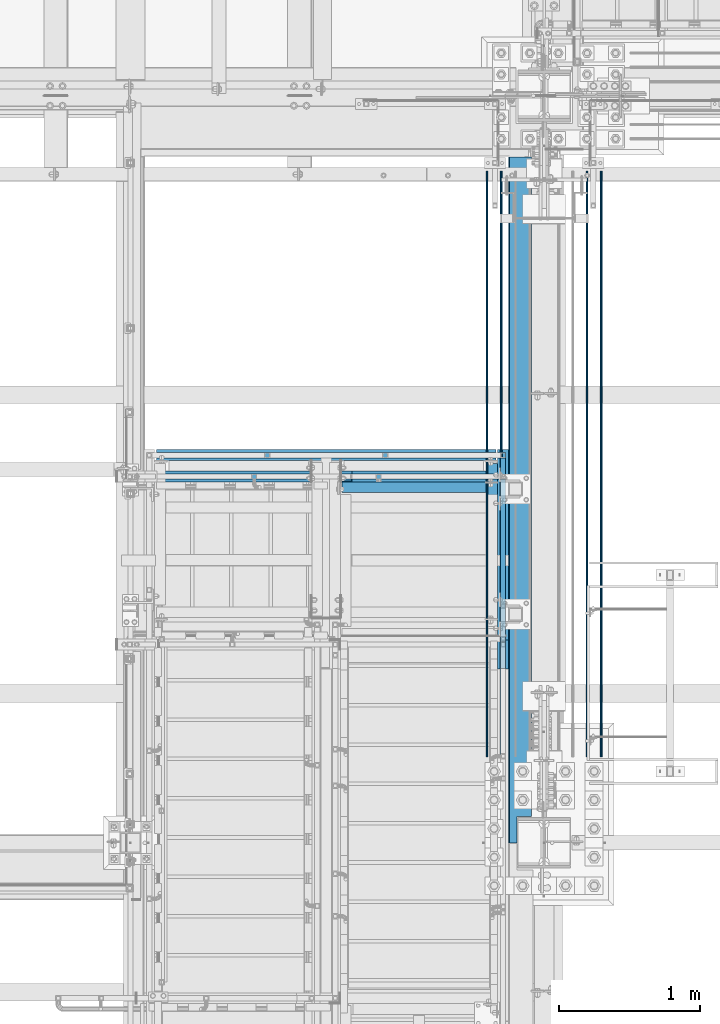
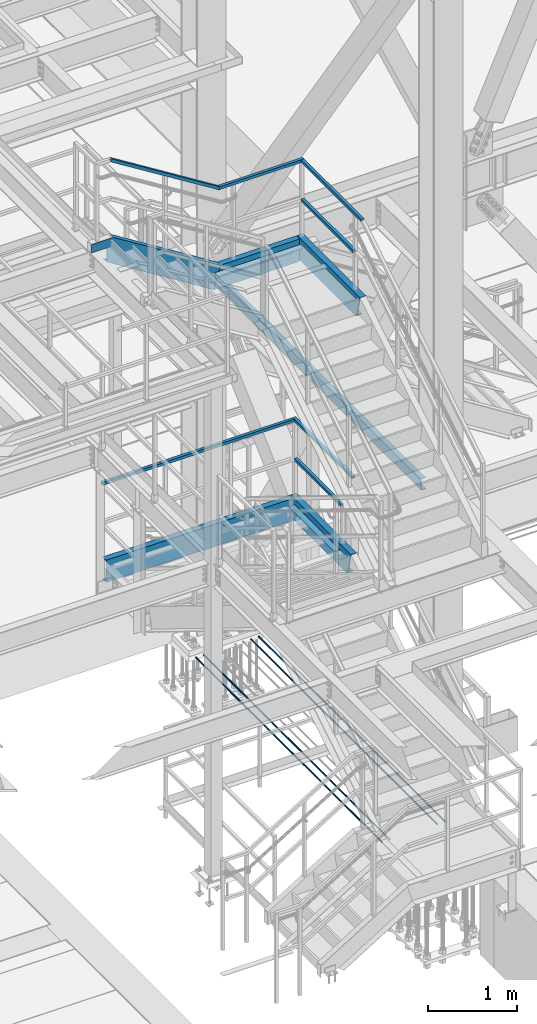
# One storey, part 1776 of 3843: 17 beams, 2 members, 13 elements without a shape of their own.
"""IFC2X3 building model written with IfcOpenShell, lengths in millimetres."""

from ifc_helpers import new_model, si_unit, frame, origin_with_axes, place, context, subcontext, project, spatial, faceted_brep, material, type_object, element, aggregate, save


model = new_model("IFC2X3")

# Units and contexts
model_context = context("Model", 3, precision=1e-05, world=origin_with_axes())
body_context = subcontext(model_context, "Body", "Model", "MODEL_VIEW")
ifc_project = project(units=[si_unit("LENGTHUNIT", "METRE", prefix="MILLI"), si_unit("AREAUNIT", "SQUARE_METRE"), si_unit("VOLUMEUNIT", "CUBIC_METRE"), si_unit("MASSUNIT", "GRAM", prefix="KILO"), si_unit("TIMEUNIT", "SECOND"), si_unit("PLANEANGLEUNIT", "RADIAN"), si_unit("SOLIDANGLEUNIT", "STERADIAN"), si_unit("THERMODYNAMICTEMPERATUREUNIT", "DEGREE_CELSIUS"), si_unit("LUMINOUSINTENSITYUNIT", "LUMEN")], contexts=[model_context])

# Site, building, storey
site_placement = place(None, origin_with_axes())
site = spatial("IfcSite", under=ifc_project, at=site_placement, CompositionType="ELEMENT")
building_placement = place(site_placement, origin_with_axes())
building = spatial("IfcBuilding", under=site, at=building_placement, Name="Undefined", CompositionType="ELEMENT")
storey_placement = place(building_placement, origin_with_axes())
storey = spatial("IfcBuildingStorey", under=building, at=storey_placement, Name="Undefined", CompositionType="ELEMENT", Elevation=0.0)

# Assembly, beam
assembly_1_placement = place(storey_placement, origin_with_axes())
assembly_1 = element("IfcElementAssembly", 1, at=assembly_1_placement, inside=storey, Name="RAIL", AssemblyPlace="NOTDEFINED", PredefinedType="RIGID_FRAME")
ifc_material_1 = material()
beam_type_1 = type_object("IfcBeamType", Name="HSS1-1/2X1-1/2X1/4", PredefinedType="NOTDEFINED")
beam_1_placement = place(assembly_1_placement, frame((55638.7, 22910.8000000047, 37761.333331298), z_axis=(0.0, 0.0, 1.0), x_axis=(-1.0, 0.0, 0.0)))
beam_1 = element("IfcBeam", 2, at=beam_1_placement, type_object=beam_type_1, material=ifc_material_1, Name="RAIL", ObjectType="HSS1-1/2X1-1/2X1/4", context=body_context, shape_type="Brep", body=[
    faceted_brep([(12.6999993300196, 12.6999993299978, -12.6999993300014), (12.6999993300014, -12.6999993299978, -12.6999993300014), (1083.13856710227, -12.6999993300014, -12.6999993299978), (1083.13856710227, 12.6999993300014, -12.6999993299978), (-12.699999329976, -12.6999993299978, 12.6999993300014), (1075.86143299826, -12.6999993300014, 12.6999993299978), (-12.6999993300014, 12.6999993299978, 12.6999993300014), (1075.86143299826, 12.6999993300014, 12.6999993299978), (19.0499992350015, 19.0499992350015, -19.0499992350015), (-19.0499992350015, 19.0499992350015, 19.0499992350015), (1074.0421494035, 19.0499992350015, 19.0499992350015), (1084.95785069704, 19.0499992350015, -19.0499992350015), (-19.0499992349796, -19.0499992350015, 19.0499992350015), (1074.0421494035, -19.0499992350015, 19.0499992350015), (19.0499992350015, -19.0499992350015, -19.0499992350015), (1084.95785069704, -19.0499992350015, -19.0499992350015)], [[[0, 1, 2, 3]], [[1, 4, 5, 2]], [[4, 6, 7, 5]], [[6, 0, 3, 7]], [[8, 9, 10, 11]], [[9, 12, 13, 10]], [[12, 14, 15, 13]], [[14, 8, 11, 15]], [[13, 15, 11, 10], [5, 7, 3, 2]], [[14, 12, 9, 8], [6, 4, 1, 0]]]),
])

# Assembly, beams
assembly_2_placement = place(storey_placement, origin_with_axes())
assembly_2 = element("IfcElementAssembly", 3, at=assembly_2_placement, inside=storey, Name="RAIL", AssemblyPlace="NOTDEFINED", PredefinedType="RIGID_FRAME")
beam_2_placement = place(assembly_2_placement, frame((55638.7, 21717.0000000047, 37227.933331298), z_axis=(0.0, 0.0, 1.0), x_axis=(0.0, 1.0, 0.0)))
beam_2 = element("IfcBeam", 4, at=beam_2_placement, type_object=beam_type_1, material=ifc_material_1, Name="RAIL", ObjectType="HSS1-1/2X1-1/2X1/4", context=body_context, shape_type="Brep", body=[
    faceted_brep([(1174.75000001042, -19.0500000010288, 19.0499992350015), (1174.75000001042, -19.0499992350015, -19.0499992350015), (1174.74999999997, 19.0499992350015, -19.0499992350015), (1174.74999999997, 19.0499992350015, 19.0499992350015), (1174.75000001042, -12.6999993299978, 12.6999993299978), (1174.75000001042, 12.6999993299978, 12.6999993299978), (1174.75000001042, 12.6999993299978, -12.6999993299978), (1174.75000001042, -12.6999993299978, -12.6999993299978), (19.0499992350015, 19.0499992350015, 19.0499992350015), (19.0499992350015, -19.0499992350015, 19.0499992350015), (19.0499992350015, -19.0499992350015, -19.0499992350015), (19.0499992350015, 19.0499992350015, -19.0499992350015), (19.0499992350015, 12.6999993299978, 12.6999993299978), (19.0499992350015, -12.6999993299978, 12.6999993299978), (19.0499992350015, -12.6999993299978, -12.6999993299978), (19.0499992350015, 12.6999993299978, -12.6999993299978)], [[[0, 1, 2, 3], [4, 5, 6, 7]], [[8, 9, 0, 3]], [[10, 11, 2, 1]], [[9, 10, 1, 0]], [[11, 8, 3, 2]], [[10, 9, 8, 11], [12, 13, 14, 15]], [[14, 13, 4, 7]], [[15, 14, 7, 6]], [[12, 15, 6, 5]], [[13, 12, 5, 4]]]),
])
beam_3_placement = place(assembly_2_placement, frame((55638.7, 22910.8000000047, 37761.333331298), z_axis=(0.0, 0.0, -1.0), x_axis=(0.0, -1.0, 0.0)))
beam_3 = element("IfcBeam", 5, at=beam_3_placement, type_object=beam_type_1, material=ifc_material_1, Name="RAIL", ObjectType="HSS1-1/2X1-1/2X1/4", context=body_context, shape_type="Brep", body=[
    faceted_brep([(19.0499992350015, 12.6999993299978, -12.6999993299978), (19.0499992350015, -12.6999993299978, -12.6999993299978), (1362.53856701089, -12.6999993299978, -12.6999993299978), (1362.53856701089, 12.6999993299978, -12.6999993299978), (19.0499992350015, -12.6999993299978, 12.6999993299978), (1355.26143290688, -12.6999993299978, 12.6999993299978), (19.0499992350015, 12.6999993299978, 12.6999993299978), (1355.26143290688, 12.6999993299978, 12.6999993299978), (19.0499992350015, 19.0499992350015, -19.0499992350015), (19.0499992350015, 19.0499992350015, 19.0499992350015), (1353.44214931212, 19.0499992350015, 19.0499992350015), (1364.35785060565, 19.0499992350015, -19.0499992350015), (19.0499992350015, -19.0499992350015, 19.0499992350015), (1353.44214931212, -19.0499992350015, 19.0499992350015), (19.0499992350015, -19.0499992350015, -19.0499992350015), (1364.35785060565, -19.0499992350015, -19.0499992350015)], [[[0, 1, 2, 3]], [[1, 4, 5, 2]], [[4, 6, 7, 5]], [[6, 0, 3, 7]], [[8, 9, 10, 11]], [[9, 12, 13, 10]], [[12, 14, 15, 13]], [[14, 8, 11, 15]], [[13, 15, 11, 10], [5, 7, 3, 2]], [[14, 12, 9, 8], [6, 4, 1, 0]]]),
])
aggregate(assembly_2, [beam_2, beam_3])

# Assembly, beam
assembly_3_placement = place(storey_placement, origin_with_axes())
assembly_3 = element("IfcElementAssembly", 6, at=assembly_3_placement, inside=storey, Name="RAIL", AssemblyPlace="NOTDEFINED", PredefinedType="RIGID_FRAME")
beam_4_placement = place(assembly_3_placement, frame((55638.6999999997, 23063.2000000032, 34125.8769212707), z_axis=(0.0, 0.0, -1.0), x_axis=(-1.0, 0.0, 0.0)))
beam_4 = element("IfcBeam", 7, at=beam_4_placement, type_object=beam_type_1, material=ifc_material_1, Name="RAIL", ObjectType="HSS1-1/2X1-1/2X1/4", context=body_context, shape_type="Brep", body=[
    faceted_brep([(19.0499992350015, 12.6999993299978, -12.6999993299978), (19.0499992350015, -12.6999993299978, -12.6999993299978), (2495.55000076468, -12.6999993300014, -12.6999993299978), (2495.55000076468, 12.6999993300014, -12.6999993299978), (19.0499992350015, -12.6999993299978, 12.6999993299978), (2495.55000076468, -12.6999993300014, 12.6999993299978), (19.0499992350015, 12.6999993299978, 12.6999993299978), (2495.55000076468, 12.6999993300014, 12.6999993299978), (19.0499992350015, 19.0499992350015, -19.0499992350015), (19.0499992350015, 19.0499992350015, 19.0499992350015), (2495.55000076468, 19.0499992350015, 19.0499992350015), (2495.55000076468, 19.0499992350015, -19.0499992350015), (19.0499992350015, -19.0499992350015, 19.0499992350015), (2495.55000076468, -19.0499992350015, 19.0499992350015), (19.0499992350015, -19.0499992350015, -19.0499992350015), (2495.55000076468, -19.0499992350015, -19.0499992350015)], [[[0, 1, 2, 3]], [[1, 4, 5, 2]], [[4, 6, 7, 5]], [[6, 0, 3, 7]], [[8, 9, 10, 11]], [[9, 12, 13, 10]], [[12, 14, 15, 13]], [[14, 8, 11, 15]], [[13, 15, 11, 10], [5, 7, 3, 2]], [[14, 12, 9, 8], [6, 4, 1, 0]]]),
])
aggregate(assembly_3, [beam_4])

# Assembly, beams
assembly_4_placement = place(storey_placement, origin_with_axes())
assembly_4 = element("IfcElementAssembly", 8, at=assembly_4_placement, inside=storey, Name="RAIL", AssemblyPlace="NOTDEFINED", PredefinedType="RIGID_FRAME")
beam_5_placement = place(assembly_4_placement, frame((55638.7000000001, 21993.2250000126, 33592.4769212961), z_axis=(0.0, 0.0, 1.0), x_axis=(0.0, 1.0, 0.0)))
beam_5 = element("IfcBeam", 9, at=beam_5_placement, type_object=beam_type_1, material=ifc_material_1, Name="RAIL", ObjectType="HSS1-1/2X1-1/2X1/4", context=body_context, shape_type="Brep", body=[
    faceted_brep([(19.0499992350015, 12.6999993299978, -12.6999993299978), (19.0499992350015, -12.6999993299978, -12.6999993299978), (1050.92500075131, -12.6999993299978, -12.6999993299978), (1050.92500075131, 12.6999993299978, -12.6999993299978), (19.0499992350015, -12.6999993299978, 12.6999993299978), (1050.92500075131, -12.6999993299978, 12.6999993299978), (19.0499992350015, 12.6999993299978, 12.6999993299978), (1050.92500075131, 12.6999993299978, 12.6999993299978), (19.0499992350015, 19.0499992350015, -19.0499992350015), (19.0499992350015, 19.0499992350015, 19.0499992350015), (1050.92500075131, 19.0499992350015, 19.0499992350015), (1050.92500075131, 19.0499992350015, -19.0499992350015), (19.0499992350015, -19.0499992350015, 19.0499992350015), (1050.92500075131, -19.0499992350015, 19.0499992350015), (19.0499992350015, -19.0499992350015, -19.0499992350015), (1050.92500075131, -19.0499992350015, -19.0499992350015)], [[[0, 1, 2, 3]], [[1, 4, 5, 2]], [[4, 6, 7, 5]], [[6, 0, 3, 7]], [[8, 9, 10, 11]], [[9, 12, 13, 10]], [[12, 14, 15, 13]], [[14, 8, 11, 15]], [[13, 15, 11, 10], [5, 7, 3, 2]], [[14, 12, 9, 8], [6, 4, 1, 0]]]),
])
beam_6_placement = place(assembly_4_placement, frame((55638.6999999997, 23063.2000000032, 34125.8769212707), z_axis=(0.0, 0.0, -1.0), x_axis=(0.0, -1.0, 0.0)))
beam_6 = element("IfcBeam", 10, at=beam_6_placement, type_object=beam_type_1, material=ifc_material_1, Name="RAIL", ObjectType="HSS1-1/2X1-1/2X1/4", context=body_context, shape_type="Brep", body=[
    faceted_brep([(-12.6999993309546, 12.6999993299978, -12.6999993299978), (-12.6999993309546, -12.6999993299978, -12.6999993299978), (1311.69463514075, -12.6999993299978, -12.6999993299978), (1311.69463514075, 12.6999993299978, -12.6999993299978), (12.6999993290483, -12.6999993299978, 12.6999993299978), (1304.50536389938, -12.6999993299978, 12.6999993299978), (12.6999993290483, 12.6999993299978, 12.6999993299978), (1304.50536389938, 12.6999993299978, 12.6999993299978), (-19.0499992359546, 19.0499992350015, -19.0499992350015), (19.0499992350015, 19.0499992350015, 19.0499992350015), (1302.70804602111, 19.0499992350015, 19.0499992350015), (1313.49195301902, 19.0499992350015, -19.0499992350015), (19.0499992350015, -19.0499992350015, 19.0499992350015), (1302.70804602111, -19.0499992350015, 19.0499992350015), (-19.0499992359546, -19.0499992350015, -19.0499992350015), (1313.49195301902, -19.0499992350015, -19.0499992350015)], [[[0, 1, 2, 3]], [[1, 4, 5, 2]], [[4, 6, 7, 5]], [[6, 0, 3, 7]], [[8, 9, 10, 11]], [[9, 12, 13, 10]], [[12, 14, 15, 13]], [[14, 8, 11, 15]], [[13, 15, 11, 10], [5, 7, 3, 2]], [[14, 12, 9, 8], [6, 4, 1, 0]]]),
])
aggregate(assembly_4, [beam_5, beam_6])

# Member
member_type_1 = type_object("IfcMemberType", Name="HSS1-1/2X1-1/2X1/4", PredefinedType="NOTDEFINED")
member_1_placement = place(assembly_1_placement, frame((53162.1999991106, 22910.8000000151, 38633.3999983557), z_axis=(-0.529536736899114, 0.0, -0.848287005838377), x_axis=(0.848287005838377, 0.0, -0.529536736899114)))
member_1 = element("IfcMember", 11, at=member_1_placement, type_object=member_type_1, material=ifc_material_1, Name="RAIL", ObjectType="HSS1-1/2X1-1/2X1/4", context=body_context, shape_type="Brep", body=[
    faceted_brep([(-3.63856705526268, 12.6999993300014, -12.6999993299469), (-3.63856705526268, -12.6999993300014, -12.6999993299469), (1643.20971803503, -12.6999993300014, -12.699999331875), (1643.20971803503, 12.6999993300014, -12.699999331875), (3.63856705247599, -12.6999993300014, 12.6999993299542), (1650.48685214277, -12.6999993300014, 12.699999328026), (3.63856705247599, 12.6999993300014, 12.6999993299542), (1650.48685214277, 12.6999993300014, 12.699999328026), (-5.45785065095697, 19.0499992350015, -19.0499992349214), (5.45785064817028, 19.0499992350015, 19.0499992349287), (1652.30613573846, 19.0499992350015, 19.0499992329933), (1641.39043443933, 19.0499992350015, -19.0499992368568), (5.45785064817028, -19.0499992350015, 19.0499992349287), (1652.30613573846, -19.0499992350015, 19.0499992329933), (-5.45785065095697, -19.0499992350015, -19.0499992349214), (1641.39043443933, -19.0499992350015, -19.0499992368568)], [[[0, 1, 2, 3]], [[1, 4, 5, 2]], [[4, 6, 7, 5]], [[6, 0, 3, 7]], [[8, 9, 10, 11]], [[9, 12, 13, 10]], [[12, 14, 15, 13]], [[14, 8, 11, 15]], [[13, 15, 11, 10], [5, 7, 3, 2]], [[14, 12, 9, 8], [6, 4, 1, 0]]]),
])

aggregate(assembly_1, [beam_1, member_1])

# Assembly, beam
assembly_5_placement = place(storey_placement, origin_with_axes())
assembly_5 = element("IfcElementAssembly", 12, at=assembly_5_placement, inside=storey, Name="STAIR", AssemblyPlace="NOTDEFINED", PredefinedType="RIGID_FRAME")
ifc_material_2 = material(Name="STEEL/A36")
beam_type_2 = type_object("IfcBeamType", Name="C12X20.7", PredefinedType="NOTDEFINED")
beam_7_placement = place(assembly_5_placement, frame((55600.5999999997, 22910.8000000628, 36567.5333312657), z_axis=(0.0, 0.0, 1.0), x_axis=(-1.0, 0.0, 0.0)))
beam_7 = element("IfcBeam", 13, at=beam_7_placement, type_object=beam_type_2, material=ifc_material_2, Name="STAIR", ObjectType="C12X20.7", context=body_context, shape_type="Brep", body=[
    faceted_brep([(12.7000000007174, 38.0999999999985, -152.400000000001), (12.7000000007174, 38.0999999999985, 152.400000000001), (1034.12286550141, 38.0999999999985, 152.400000000001), (1121.44847935647, 38.0999999999985, -152.400000000001), (12.7000000007174, -38.0999999999985, 152.400000000001), (1034.12286550141, -38.0999999999985, 152.400000000001), (12.7000000007174, -38.0999999999985, 146.047460000002), (1035.94287683684, -38.0999999999985, 146.047460000002), (12.7000000007174, 30.1624999999985, 134.674927499997), (1039.20112283962, 30.1624999999985, 134.674927499997), (12.7000000007174, 30.1624999999985, -134.674927499997), (1116.37022201826, 30.1624999999985, -134.674927499997), (12.7000000007174, -38.0999999999985, -146.047460000002), (1119.62846802104, -38.0999999999985, -146.047460000002), (12.7000000007174, -38.0999999999985, -152.400000000001), (1121.44847935647, -38.0999999999985, -152.400000000001)], [[[0, 1, 2, 3]], [[1, 4, 5, 2]], [[4, 6, 7, 5]], [[6, 8, 9, 7]], [[8, 10, 11, 9]], [[10, 12, 13, 11]], [[12, 14, 15, 13]], [[14, 0, 3, 15]], [[5, 7, 9, 11, 13, 15, 3, 2]], [[14, 12, 10, 8, 6, 4, 1, 0]]]),
])

assembly_6_placement = place(storey_placement, origin_with_axes())
assembly_6 = element("IfcElementAssembly", 14, at=assembly_6_placement, inside=storey, Name="STAIR", AssemblyPlace="NOTDEFINED", PredefinedType="RIGID_FRAME")
beam_8_placement = place(assembly_6_placement, frame((53162.1999999984, 23063.2000000006, 32932.0769213273), z_axis=(0.0, 0.0, -1.0), x_axis=(1.0, 0.0, 0.0)))
beam_8 = element("IfcBeam", 15, at=beam_8_placement, type_object=beam_type_2, material=ifc_material_2, Name="STAIR", ObjectType="C12X20.7", context=body_context, shape_type="Brep", body=[
    faceted_brep([(12.7000000007174, 38.0999999999985, -152.400000000001), (12.7000000007174, 38.0999999999985, 152.400000000001), (2425.70000000265, 38.0999999999985, 152.400000000001), (2425.70000000265, 38.0999999999985, -152.400000000001), (12.7000000007174, -38.0999999999985, 152.400000000001), (2425.70000000265, -38.0999999999985, 152.400000000001), (12.7000000007174, -38.0999999999985, 146.047460000002), (2425.70000000265, -38.0999999999985, 146.047460000002), (12.7000000007174, 30.1624999999985, 134.674927499997), (2425.70000000265, 30.1624999999985, 134.674927499997), (12.7000000007174, 30.1624999999985, -134.674927499997), (2425.70000000265, 30.1624999999985, -134.674927499997), (12.7000000007174, -38.0999999999985, -146.047460000002), (2425.70000000265, -38.0999999999985, -146.047460000002), (12.7000000007174, -38.0999999999985, -152.400000000001), (2425.70000000265, -38.0999999999985, -152.400000000001)], [[[0, 1, 2, 3]], [[1, 4, 5, 2]], [[4, 6, 7, 5]], [[6, 8, 9, 7]], [[8, 10, 11, 9]], [[10, 12, 13, 11]], [[12, 14, 15, 13]], [[14, 0, 3, 15]], [[5, 7, 9, 11, 13, 15, 3, 2]], [[14, 12, 10, 8, 6, 4, 1, 0]]]),
])
aggregate(assembly_6, [beam_8])

assembly_7_placement = place(storey_placement, origin_with_axes())
assembly_7 = element("IfcElementAssembly", 16, at=assembly_7_placement, inside=storey, Name="STAIR", AssemblyPlace="NOTDEFINED", PredefinedType="RIGID_FRAME")
beam_9_placement = place(assembly_7_placement, frame((55638.699999999, 21544.622865497, 36567.5333312459), z_axis=(0.0, 0.0, 1.0), x_axis=(0.0, 1.0, 0.0)))
beam_9 = element("IfcBeam", 17, at=beam_9_placement, type_object=beam_type_2, material=ifc_material_2, Name="STAIR", ObjectType="C12X20.7", context=body_context, shape_type="Brep", body=[
    faceted_brep([(87.3256158388394, 38.0999999999985, -152.400000000001), (0.0, 38.0999999999985, 152.400000000001), (1404.27713447458, 38.0999999999985, 152.400000000001), (1404.27713446714, 38.0999999999985, -152.400000000001), (0.0, -38.0999999999985, 152.400000000001), (1404.27713447458, -38.0999999999985, 152.400000000001), (1.82001331920401, -38.0999999999985, 146.047460000002), (1404.27713446714, -38.0999999999985, 146.047460000002), (5.0782593219883, 30.1624999999985, 134.674927499997), (1404.27713446714, 30.1624999999985, 134.674927499997), (82.2473585006228, 30.1624999999985, -134.674927499997), (1404.27713446714, 30.1624999999985, -134.674927499997), (85.5056045034071, -38.0999999999985, -146.047460000002), (1404.27713446714, -38.0999999999985, -146.047460000002), (87.3256158388394, -38.0999999999985, -152.400000000001), (1404.27713446714, -38.0999999999985, -152.400000000001)], [[[0, 1, 2, 3]], [[1, 4, 5, 2]], [[4, 6, 7, 5]], [[6, 8, 9, 7]], [[8, 10, 11, 9]], [[10, 12, 13, 11]], [[12, 14, 15, 13]], [[14, 0, 3, 15]], [[5, 7, 9, 11, 13, 15, 3, 2]], [[14, 12, 10, 8, 6, 4, 1, 0]]]),
])
aggregate(assembly_7, [beam_9])

assembly_8_placement = place(storey_placement, origin_with_axes())
assembly_8 = element("IfcElementAssembly", 18, at=assembly_8_placement, inside=storey, Name="STAIR", AssemblyPlace="NOTDEFINED", PredefinedType="RIGID_FRAME")
beam_10_placement = place(assembly_8_placement, frame((55638.700000001, 21747.9107283699, 32932.0769213161), z_axis=(0.0, 0.0, 1.0), x_axis=(0.0, 1.0, 0.0)))
beam_10 = element("IfcBeam", 19, at=beam_10_placement, type_object=beam_type_2, material=ifc_material_2, Name="STAIR", ObjectType="C12X20.7", context=body_context, shape_type="Brep", body=[
    faceted_brep([(86.2712597135396, 38.0999999999985, -152.39999999988), (0.0, 38.0999999999985, 152.400000000001), (1353.38927165531, 38.0999999999985, 152.400000000001), (1353.38927162904, 38.0999999999985, -152.400000000001), (0.0, -38.0999999999985, 152.400000000001), (1353.38927165531, -38.0999999999985, 152.400000000001), (1.79803683332284, -38.0999999999985, 146.047459999862), (1353.38927162904, -38.0999999999985, 146.047460000002), (5.01694334564672, 30.1624999999985, 134.674927499867), (1353.38927162904, 30.1624999999985, 134.674927499997), (81.2543163632508, 30.1624999999985, -134.674927499889), (1353.38927162904, 30.1624999999985, -134.674927499997), (84.4732228755893, -38.0999999999985, -146.047459999883), (1353.38927162904, -38.0999999999985, -146.047460000002), (86.2712597135396, -38.0999999999985, -152.39999999988), (1353.38927162904, -38.0999999999985, -152.400000000001)], [[[0, 1, 2, 3]], [[1, 4, 5, 2]], [[4, 6, 7, 5]], [[6, 8, 9, 7]], [[8, 10, 11, 9]], [[10, 12, 13, 11]], [[12, 14, 15, 13]], [[14, 0, 3, 15]], [[5, 7, 9, 11, 13, 15, 3, 2]], [[14, 12, 10, 8, 6, 4, 1, 0]]]),
])

# Member
member_type_2 = type_object("IfcMemberType", Name="C12X20.7", PredefinedType="NOTDEFINED")
member_2_placement = place(assembly_5_placement, frame((54485.7757357471, 22910.8000000816, 36590.654391611), z_axis=(0.529536736899108, 0.0, 0.848287005838381), x_axis=(-0.848287005838377, 0.0, 0.529536736899114)))
member_2 = element("IfcMember", 20, at=member_2_placement, type_object=member_type_2, material=ifc_material_2, Name="STAIR", ObjectType="C12X20.7", context=body_context, shape_type="Brep", body=[
    faceted_brep([(1551.07929866942, 30.1624999999985, -134.674927501343), (1543.98008141293, -38.0999999999985, -146.047460001297), (1540.01455644384, -38.0999999999985, -152.400000001267), (1540.01455644384, 38.0999999999985, -152.400000001267), (1642.99900140413, 38.0999999999985, 12.575081755771), (1642.99900140413, 30.1624999999985, 12.575081755771), (1815.37092098931, 30.1624999999985, -95.0267831813981), (1815.37092098931, 38.0999999999985, -95.0267831813981), (0.0, -38.0999999999985, 152.400000000001), (-1.82001139405475, -38.0999999999985, 146.047459999492), (1645.03307064007, -38.0999999999985, 146.047459997571), (1634.85667160945, -38.0999999999985, 152.399999997557), (0.0, 38.0999999999985, 152.400000000001), (1634.85667160945, 38.0999999999985, 152.399999997557), (-87.3256139575133, -38.0999999999985, -152.399999999368), (-85.5056026211532, -38.0999999999985, -146.04745999939), (-82.2473566166918, 30.1624999999985, -134.674927499429), (-5.07825739850887, 30.1624999999985, 134.674927499538), (-87.3256139575133, 38.0999999999985, -152.399999999368), (1663.25120523013, 30.1624999999985, 134.674927497588), (1875.89696921553, 30.1624999999985, 1.93242030221154), (1875.89696921553, 38.0999999999985, 1.93242030221154)], [[[0, 1, 2, 3, 4, 5]], [[6, 5, 4, 7]], [[8, 9, 10, 11]], [[12, 8, 11, 13]], [[14, 15, 16, 17, 9, 8, 12, 18]], [[9, 17, 19, 10]], [[13, 11, 10, 19, 20, 21]], [[21, 20, 6, 7]], [[3, 18, 12, 13, 21, 7, 4]], [[14, 18, 3, 2]], [[15, 14, 2, 1]], [[16, 15, 1, 0]], [[20, 19, 17, 16, 0, 5, 6]]]),
])

# Assembly, beam
assembly_9_placement = place(storey_placement, origin_with_axes())
assembly_9 = element("IfcElementAssembly", 21, at=assembly_9_placement, inside=storey, Name="REBAR", AssemblyPlace="NOTDEFINED", PredefinedType="RIGID_FRAME")
ifc_material_3 = material(Name="STEEL/A706-60")
beam_type_3 = type_object("IfcBeamType", Name="#10 REBAR", PredefinedType="NOTDEFINED")
beam_11_placement = place(assembly_9_placement, frame((56235.6, 25082.5, 29687.8375), z_axis=(0.0, 0.0, 1.0), x_axis=(0.0, -1.0, 0.0)))
beam_11 = element("IfcBeam", 22, at=beam_11_placement, type_object=beam_type_3, material=ifc_material_3, Name="REBAR", ObjectType="#10 REBAR", context=body_context, shape_type="Brep", body=[
    faceted_brep([(0.0, -7.9375, 0.0), (0.0, -5.61266007566883, -5.61266007566883), (4165.68743163327, -5.61266007566883, -5.61266007566883), (4165.68743163327, -7.9375, 0.0), (0.0, 0.0, -7.9375), (4165.68743163327, 0.0, -7.9375), (0.0, 5.61266007566883, -5.61266007566883), (4165.68743163327, 5.61266007566883, -5.61266007566883), (0.0, 7.9375, 0.0), (4165.68743163327, 7.9375, 0.0), (0.0, 5.61266007566883, 5.61266007566883), (4165.68743163327, 5.61266007566883, 5.61266007566883), (0.0, 0.0, 7.9375), (4165.68743163327, 0.0, 7.9375), (0.0, -5.61266007566883, 5.61266007566883), (4165.68743163327, -5.61266007566883, 5.61266007566883)], [[[0, 1, 2, 3]], [[1, 4, 5, 2]], [[4, 6, 7, 5]], [[6, 8, 9, 7]], [[8, 10, 11, 9]], [[10, 12, 13, 11]], [[12, 14, 15, 13]], [[14, 0, 3, 15]], [[5, 7, 9, 11, 13, 15, 3, 2]], [[14, 12, 10, 8, 6, 4, 1, 0]]]),
])
aggregate(assembly_9, [beam_11])

assembly_10_placement = place(storey_placement, origin_with_axes())
assembly_10 = element("IfcElementAssembly", 23, at=assembly_10_placement, inside=storey, Name="REBAR", AssemblyPlace="NOTDEFINED", PredefinedType="RIGID_FRAME")
beam_12_placement = place(assembly_10_placement, frame((56337.2, 25082.5, 29687.8375), z_axis=(0.0, 0.0, 1.0), x_axis=(0.0, -1.0, 0.0)))
beam_12 = element("IfcBeam", 24, at=beam_12_placement, type_object=beam_type_3, material=ifc_material_3, Name="REBAR", ObjectType="#10 REBAR", context=body_context, shape_type="Brep", body=[
    faceted_brep([(0.0, -7.9375, 0.0), (0.0, -5.61266007566883, -5.61266007566883), (4165.68743163327, -5.61266007566883, -5.61266007566883), (4165.68743163327, -7.9375, 0.0), (0.0, 0.0, -7.9375), (4165.68743163327, 0.0, -7.9375), (0.0, 5.61266007566883, -5.61266007566883), (4165.68743163327, 5.61266007566883, -5.61266007566883), (0.0, 7.9375, 0.0), (4165.68743163327, 7.9375, 0.0), (0.0, 5.61266007566883, 5.61266007566883), (4165.68743163327, 5.61266007566883, 5.61266007566883), (0.0, 0.0, 7.9375), (4165.68743163327, 0.0, 7.9375), (0.0, -5.61266007566883, 5.61266007566883), (4165.68743163327, -5.61266007566883, 5.61266007566883)], [[[0, 1, 2, 3]], [[1, 4, 5, 2]], [[4, 6, 7, 5]], [[6, 8, 9, 7]], [[8, 10, 11, 9]], [[10, 12, 13, 11]], [[12, 14, 15, 13]], [[14, 0, 3, 15]], [[5, 7, 9, 11, 13, 15, 3, 2]], [[14, 12, 10, 8, 6, 4, 1, 0]]]),
])
aggregate(assembly_10, [beam_12])

assembly_11_placement = place(storey_placement, origin_with_axes())
assembly_11 = element("IfcElementAssembly", 25, at=assembly_11_placement, inside=storey, Name="REBAR", AssemblyPlace="NOTDEFINED", PredefinedType="RIGID_FRAME")
beam_13_placement = place(assembly_11_placement, frame((55524.4, 25082.5, 29687.8375), z_axis=(0.0, 0.0, 1.0), x_axis=(0.0, -1.0, 0.0)))
beam_13 = element("IfcBeam", 26, at=beam_13_placement, type_object=beam_type_3, material=ifc_material_3, Name="REBAR", ObjectType="#10 REBAR", context=body_context, shape_type="Brep", body=[
    faceted_brep([(0.0, -7.9375, 0.0), (0.0, -5.61266007566883, -5.61266007566883), (4165.68743163327, -5.61266007566883, -5.61266007566883), (4165.68743163327, -7.9375, 0.0), (0.0, 0.0, -7.9375), (4165.68743163327, 0.0, -7.9375), (0.0, 5.61266007566883, -5.61266007566883), (4165.68743163327, 5.61266007566883, -5.61266007566883), (0.0, 7.9375, 0.0), (4165.68743163327, 7.9375, 0.0), (0.0, 5.61266007566883, 5.61266007566883), (4165.68743163327, 5.61266007566883, 5.61266007566883), (0.0, 0.0, 7.9375), (4165.68743163327, 0.0, 7.9375), (0.0, -5.61266007566883, 5.61266007566883), (4165.68743163327, -5.61266007566883, 5.61266007566883)], [[[0, 1, 2, 3]], [[1, 4, 5, 2]], [[4, 6, 7, 5]], [[6, 8, 9, 7]], [[8, 10, 11, 9]], [[10, 12, 13, 11]], [[12, 14, 15, 13]], [[14, 0, 3, 15]], [[5, 7, 9, 11, 13, 15, 3, 2]], [[14, 12, 10, 8, 6, 4, 1, 0]]]),
])
aggregate(assembly_11, [beam_13])

assembly_12_placement = place(storey_placement, origin_with_axes())
assembly_12 = element("IfcElementAssembly", 27, at=assembly_12_placement, inside=storey, Name="REBAR", AssemblyPlace="NOTDEFINED", PredefinedType="RIGID_FRAME")
beam_14_placement = place(assembly_12_placement, frame((55626.0, 25082.5, 29687.8375), z_axis=(0.0, 0.0, 1.0), x_axis=(0.0, -1.0, 0.0)))
beam_14 = element("IfcBeam", 28, at=beam_14_placement, type_object=beam_type_3, material=ifc_material_3, Name="REBAR", ObjectType="#10 REBAR", context=body_context, shape_type="Brep", body=[
    faceted_brep([(0.0, -7.9375, 0.0), (0.0, -5.61266007566883, -5.61266007566883), (4165.68743163327, -5.61266007566883, -5.61266007566883), (4165.68743163327, -7.9375, 0.0), (0.0, 0.0, -7.9375), (4165.68743163327, 0.0, -7.9375), (0.0, 5.61266007566883, -5.61266007566883), (4165.68743163327, 5.61266007566883, -5.61266007566883), (0.0, 7.9375, 0.0), (4165.68743163327, 7.9375, 0.0), (0.0, 5.61266007566883, 5.61266007566883), (4165.68743163327, 5.61266007566883, 5.61266007566883), (0.0, 0.0, 7.9375), (4165.68743163327, 0.0, 7.9375), (0.0, -5.61266007566883, 5.61266007566883), (4165.68743163327, -5.61266007566883, 5.61266007566883)], [[[0, 1, 2, 3]], [[1, 4, 5, 2]], [[4, 6, 7, 5]], [[6, 8, 9, 7]], [[8, 10, 11, 9]], [[10, 12, 13, 11]], [[12, 14, 15, 13]], [[14, 0, 3, 15]], [[5, 7, 9, 11, 13, 15, 3, 2]], [[14, 12, 10, 8, 6, 4, 1, 0]]]),
])
aggregate(assembly_12, [beam_14])

# Beam
beam_type_4 = type_object("IfcBeamType", Name="L3X3X1/4", PredefinedType="NOTDEFINED")
beam_15_placement = place(assembly_5_placement, frame((54495.7000000005, 22834.6000000001, 36605.6333314046), z_axis=(0.0, -1.0, 0.0), x_axis=(1.0, 0.0, 0.0)))
beam_15 = element("IfcBeam", 29, at=beam_15_placement, type_object=beam_type_4, material=ifc_material_2, Name="ANGLE", ObjectType="L3X3X1/4", context=body_context, shape_type="Brep", body=[
    faceted_brep([(1003.29999998639, -38.0999999999985, -31.75), (1003.29999998639, -38.0999999999985, -38.0999999999985), (1003.29999998639, 31.7500000058208, -38.0999999999985), (1003.29999998639, 31.75, -31.75), (1092.20000022113, 31.75, -31.75), (1092.20000022113, 31.7499999999927, -38.0999999999985), (0.0, 31.75, -31.75), (0.0, -38.0999999999985, -31.75), (0.0, -38.0999999999985, -38.0999999999985), (0.0, 38.0999999999985, -38.0999999999985), (1092.20000022635, 38.0999999990308, -38.0999999999985), (0.0, 38.0999999999985, 38.0999999999985), (1092.20000022635, 38.0999999990308, 38.0999999999985), (0.0, 31.75, 38.0999999999985), (1003.29999998639, 31.75, 38.0999999999985), (1092.19999991878, 31.75, 38.0999999999985)], [[[0, 1, 2, 3]], [[4, 3, 2, 5]], [[6, 7, 0, 3]], [[7, 8, 1, 0]], [[1, 8, 9, 10, 5, 2]], [[9, 11, 12, 10]], [[8, 7, 6, 13, 11, 9]], [[11, 13, 14, 15, 12]], [[10, 12, 15, 4, 5]], [[14, 13, 6, 3, 4, 15]]]),
])

aggregate(assembly_5, [beam_15, beam_7, member_2])

beam_16_placement = place(assembly_8_placement, frame((55562.500000001, 23002.8750000002, 32970.1768417302), z_axis=(-1.0, 0.0, 0.0), x_axis=(0.0, -1.0, 0.0)))
beam_16 = element("IfcBeam", 30, at=beam_16_placement, type_object=beam_type_4, material=ifc_material_2, Name="ANGLE", ObjectType="L3X3X1/4", context=body_context, shape_type="Brep", body=[
    faceted_brep([(41.274998555833, -38.0999999999985, -31.75), (41.274998555833, -38.0999999999985, -38.0999999999985), (41.2749985560731, 25.3999999200605, -38.0999999999985), (41.2749985560731, 25.3999999200605, -31.75), (117.475000081951, 25.3999999200532, -38.0999999999985), (117.475000081951, 25.3999999200532, -31.75), (117.475000081955, -38.10000003194, -31.75), (117.475000081955, -38.0999999999985, -38.0999999999985), (0.0, 38.0999999999985, 38.0999999999985), (0.0, 31.75, 38.0999999999985), (1006.47499999683, 31.75, 38.0999999999985), (1006.47499999683, 38.0999999999985, 38.0999999999985), (0.0, 38.0999999999985, -38.0999999999985), (1006.47499999683, 38.0999999999985, -38.0999999999985), (0.0, -38.0999999999985, -38.0999999999985), (0.0, -38.0999999999985, -31.75), (0.0, 31.75, -31.75), (1006.47499999683, 31.75, -31.75), (1006.47499999691, 25.3999999200605, -31.75), (1006.47499999683, 25.3999999200605, -38.0999999999985), (930.274998471032, 25.3999999200678, -31.75), (930.274998471032, 25.3999999200678, -38.0999999999985), (930.274998470792, -38.0999999999985, -31.75), (930.274998470792, -38.0999999999985, -38.0999999999985), (320.674999918381, -38.1000000319327, -31.75), (320.674999918381, -38.0999999999985, -38.0999999999985), (320.674999918378, 25.3999999200605, -31.75), (320.674999918378, 25.3999999200605, -38.0999999999985), (244.474998392499, 25.3999999200678, -31.75), (244.474998392499, 25.3999999200678, -38.0999999999985), (244.474998392259, -38.0999999999985, -31.75), (244.474998392259, -38.0999999999985, -38.0999999999985)], [[[0, 1, 2, 3]], [[3, 2, 4, 5]], [[6, 5, 4, 7]], [[8, 9, 10, 11]], [[12, 8, 11, 13]], [[14, 15, 16, 9, 8, 12]], [[9, 16, 17, 10]], [[13, 11, 10, 17, 18, 19]], [[18, 20, 21, 19]], [[22, 23, 21, 20]], [[23, 22, 24, 25]], [[24, 26, 27, 25]], [[28, 29, 27, 26]], [[30, 31, 29, 28]], [[31, 30, 6, 7]], [[2, 1, 14, 12, 13, 19, 21, 23, 25, 27, 29, 31, 7, 4]], [[15, 14, 1, 0]], [[30, 28, 26, 24, 22, 20, 18, 17, 16, 15, 0, 3, 5, 6]]]),
])

aggregate(assembly_8, [beam_16, beam_10])

# Assembly, beam
assembly_13_placement = place(storey_placement, origin_with_axes())
assembly_13 = element("IfcElementAssembly", 31, at=assembly_13_placement, inside=storey, Name="BENT_PLATE", AssemblyPlace="NOTDEFINED", PredefinedType="RIGID_FRAME")
beam_type_5 = type_object("IfcBeamType", PredefinedType="NOTDEFINED")
beam_17_placement = place(assembly_13_placement, frame((55841.9, 22744.112, 34813.875), z_axis=(0.0, -1.0, 0.0), x_axis=(-1.0, 0.0, 0.0)))
beam_17 = element("IfcBeam", 32, at=beam_17_placement, type_object=beam_type_5, material=ifc_material_2, Name="BENT_PLATE", context=body_context, shape_type="Brep", body=[
    faceted_brep([(103.187501525877, -3.17500000000291, 2247.9302690344), (103.187501525877, 3.17500000000291, 2247.9302690344), (0.0, 3.17500000000291, 2247.9302690344), (0.0, -3.17500000000291, 2247.9302690344), (103.1875, -3.17500000000291, 2436.8125), (103.1875, 3.17500000000291, 2436.8125), (165.100006103516, 3.17500000000291, 2436.8125), (165.100006103516, -136.524996948239, 2436.8125), (165.100006468892, -136.524996948239, 868.362005232837), (165.100006103516, 3.17500000000291, 868.362005232837), (158.75000610351, -136.524996948239, 2436.8125), (158.75000610351, -136.524996948239, 868.362004747767), (165.100006103516, 3.17500000000291, 754.062000273167), (165.100006103516, -136.524996948239, 754.062000273167), (165.1000064689, -136.524996948239, -20.6379948456888), (165.100006103516, 3.17500000000291, -20.6379948456888), (158.75000610351, -136.524996948239, 754.062000063223), (158.75000610351, -136.524996948239, -20.6379953307587), (158.75000610351, -3.17500000000291, -2436.8125), (0.0, -3.17500000000291, -2436.8125), (0.0, 3.17500000000291, -2436.8125), (165.100006103516, 3.17500000000291, -2436.8125), (165.100006103516, -136.524996948239, -2436.8125), (158.75000610351, -136.524996948239, -2436.8125), (165.100006103516, 3.17500000000291, -134.937999805359), (165.100006103516, -136.524996948239, -134.937999805359), (158.75000610351, -136.524996948239, -134.938000015303), (158.75000610351, -3.17500000000291, -134.938000015303), (50.8009960196869, 3.17500000000291, -134.938003577266), (50.8009960196869, -3.17500000000291, -134.938003577266), (50.801002861117, 3.17500000000291, -20.63800357726), (50.801002861117, -3.17500000000291, -20.63800357726), (158.75000610351, -3.17500000000291, -20.6379953307587), (158.75000610351, -3.17500000000291, 754.062000063223), (50.8009960196869, 3.17500000000291, 754.061996501259), (50.8009960196869, -3.17500000000291, 754.061996501259), (50.8010028611025, 3.17500000000291, 868.361996501266), (50.8010028611025, -3.17500000000291, 868.361996501266), (158.75000610351, -3.17500000000291, 868.362004747767), (158.75000610351, -3.17500000000291, 2436.8125)], [[[0, 1, 2, 3]], [[4, 5, 1, 0]], [[6, 7, 8, 9]], [[7, 10, 11, 8]], [[12, 13, 14, 15]], [[13, 16, 17, 14]], [[18, 19, 20, 21, 22, 23]], [[22, 21, 24, 25]], [[23, 22, 25, 26]], [[18, 23, 26, 27]], [[25, 24, 28, 29, 27, 26]], [[29, 28, 30, 31]], [[14, 17, 32, 31, 30, 15]], [[16, 33, 32, 17]], [[13, 12, 34, 35, 33, 16]], [[35, 34, 36, 37]], [[8, 11, 38, 37, 36, 9]], [[10, 39, 38, 11]], [[3, 19, 18, 27, 29, 31, 32, 33, 35, 37, 38, 39, 4, 0]], [[20, 19, 3, 2]], [[6, 9, 36, 34, 12, 15, 30, 28, 24, 21, 20, 2, 1, 5]], [[39, 10, 7, 6, 5, 4]]]),
])
aggregate(assembly_13, [beam_17])

save(model, "model.ifc")
